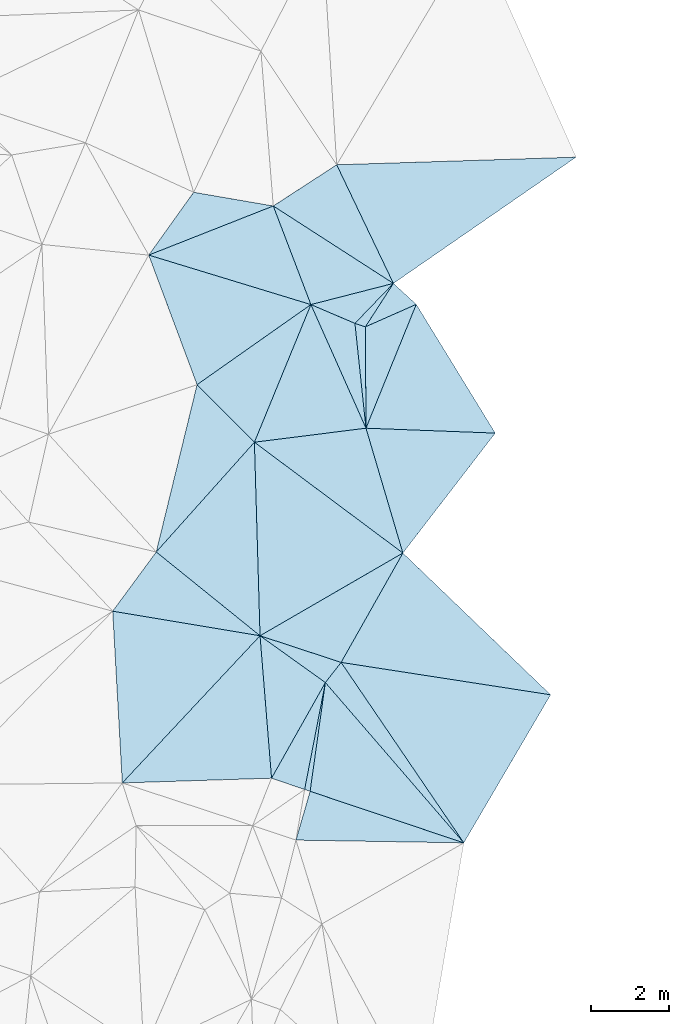
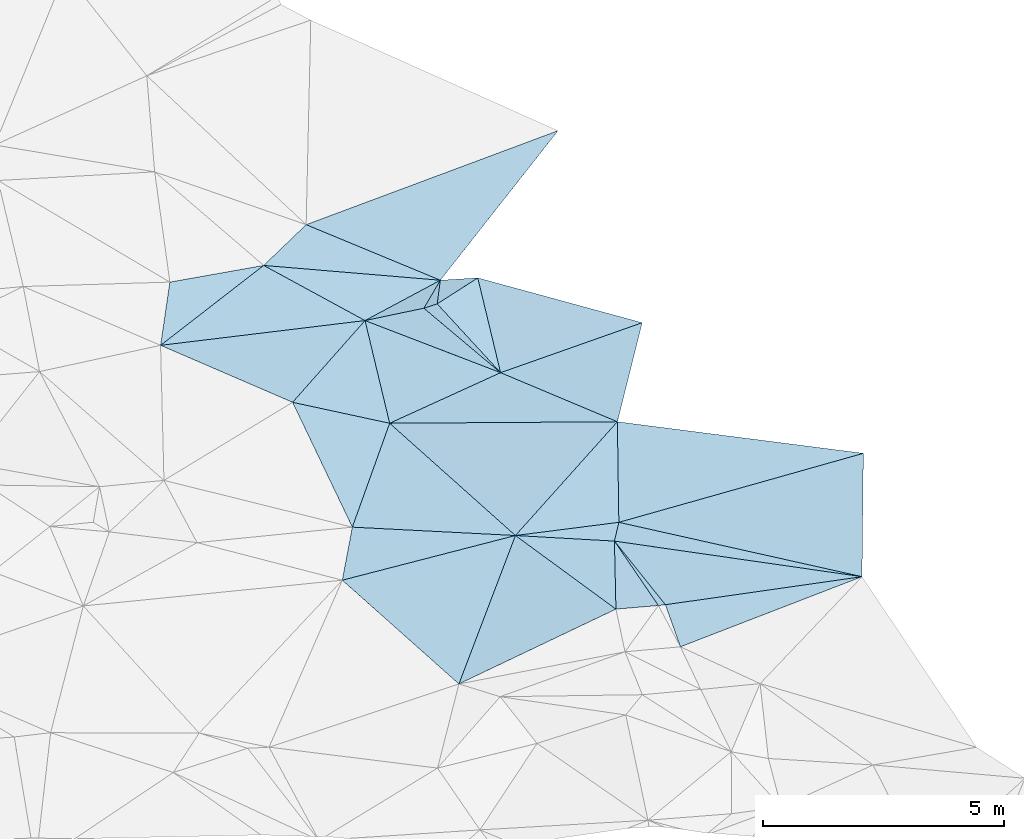
# One storey, part 120 of 275: 33 plates.
"""IFC2X3 building model written with IfcOpenShell, lengths in millimetres."""

from ifc_helpers import new_model, si_unit, frame, origin_with_axes, place, context, subcontext, project, spatial, polyline, outline, extrude, material, type_object, element, save


model = new_model("IFC2X3")

# Units and contexts
model_context = context("Model", 3, precision=1e-05, world=origin_with_axes())
body_context = subcontext(model_context, "Body", "Model", "MODEL_VIEW")
ifc_project = project(units=[si_unit("LENGTHUNIT", "METRE", prefix="MILLI"), si_unit("AREAUNIT", "SQUARE_METRE"), si_unit("VOLUMEUNIT", "CUBIC_METRE"), si_unit("MASSUNIT", "GRAM", prefix="KILO"), si_unit("TIMEUNIT", "SECOND"), si_unit("PLANEANGLEUNIT", "RADIAN"), si_unit("SOLIDANGLEUNIT", "STERADIAN"), si_unit("THERMODYNAMICTEMPERATUREUNIT", "DEGREE_CELSIUS"), si_unit("LUMINOUSINTENSITYUNIT", "LUMEN")], contexts=[model_context])

# Site, building, storey
site_placement = place(None, origin_with_axes())
site = spatial("IfcSite", under=ifc_project, at=site_placement, CompositionType="ELEMENT")
building_placement = place(site_placement, origin_with_axes())
building = spatial("IfcBuilding", under=site, at=building_placement, Name="Undefined", CompositionType="ELEMENT")
storey_placement = place(building_placement, origin_with_axes())
storey = spatial("IfcBuildingStorey", under=building, at=storey_placement, Name="Undefined", CompositionType="ELEMENT", Elevation=0.0)

# Plates
ifc_material = material()
plate_type_1 = type_object("IfcPlateType", PredefinedType="NOTDEFINED")
plate_1_placement = place(storey_placement, frame((-31947.0764014993, 99739.4786818844, 45259.501413125), z_axis=(-0.0397903641696847, 0.0634790782564287, -0.997189617646994), x_axis=(0.83857300788304, -0.54054492477612, -0.067871162865909)))
element("IfcPlate", 1, at=plate_1_placement, inside=storey, type_object=plate_type_1, material=ifc_material, Name="00", context=body_context, shape_type="SweptSolid", body=[
    extrude(outline(polyline([(0.0, 0.0), (3683.44946289063, 2.40106601268053e-09), (2195.46923828125, 1607.36267089844), (0.0, 0.0)])), frame((-8.85201319254618e-08, 2.18876761149539e-07, -0.5000001331573), z_axis=(0.0, 0.0, 1.0), x_axis=(1.0, 0.0, 0.0)), (0.0, 0.0, 1.0), 1.0),
])
plate_type_2 = type_object("IfcPlateType", PredefinedType="NOTDEFINED")
plate_2_placement = place(storey_placement, frame((-32287.5102450675, 88688.02246184, 45229.5048028609), z_axis=(0.125688742627782, -0.057425887442176, -0.990406284020919), x_axis=(0.0804682931812958, -0.994443692263625, 0.0678719139967147)))
element("IfcPlate", 2, at=plate_2_placement, inside=storey, type_object=plate_type_2, material=ifc_material, Name="00", context=body_context, shape_type="SweptSolid", body=[
    extrude(outline(polyline([(0.0, 0.0), (3683.40869140625, 2.38469510804862e-08), (3463.72094726563, 3863.85009765625), (0.0, 0.0)])), frame((-8.85201319254618e-08, 2.18876761149539e-07, -0.5000001331573), z_axis=(0.0, 0.0, 1.0), x_axis=(1.0, 0.0, 0.0)), (0.0, 0.0, 1.0), 1.0),
])
plate_type_3 = type_object("IfcPlateType", PredefinedType="NOTDEFINED")
plate_3_placement = place(storey_placement, frame((-24815.5225647739, 87169.6801998896, 45619.5023801099), z_axis=(0.0774642801000409, 0.058872677691783, -0.99525539090727), x_axis=(-0.985984849721847, 0.152470968813586, -0.0677235541597923)))
element("IfcPlate", 3, at=plate_3_placement, inside=storey, type_object=plate_type_3, material=ifc_material, Name="00", context=body_context, shape_type="SweptSolid", body=[
    extrude(outline(polyline([(0.0, 0.0), (5463.38720703125, -1.55705492943525e-09), (4306.3759765625, 3029.59155273438), (0.0, 0.0)])), frame((-8.85201319254618e-08, 2.18876761149539e-07, -0.5000001331573), z_axis=(0.0, 0.0, 1.0), x_axis=(1.0, 0.0, 0.0)), (0.0, 0.0, 1.0), 1.0),
])
plate_type_4 = type_object("IfcPlateType", PredefinedType="NOTDEFINED")
plate_4_placement = place(storey_placement, frame((-28858.2627816434, 97748.3657133322, 45009.502403774), z_axis=(-0.0951402428778409, -0.0226368225865186, -0.995206465236401), x_axis=(-0.838573007906476, 0.540544924740473, 0.067871162860247)))
element("IfcPlate", 4, at=plate_4_placement, inside=storey, type_object=plate_type_4, material=ifc_material, Name="00", context=body_context, shape_type="SweptSolid", body=[
    extrude(outline(polyline([(0.0, 0.0), (3683.44946289063, 2.40106601268053e-09), (2876.67846679688, 1778.76940917969), (0.0, 0.0)])), frame((-8.85201319254618e-08, 2.18876761149539e-07, -0.5000001331573), z_axis=(0.0, 0.0, 1.0), x_axis=(1.0, 0.0, 0.0)), (0.0, 0.0, 1.0), 1.0),
])
plate_type_5 = type_object("IfcPlateType", PredefinedType="NOTDEFINED")
plate_5_placement = place(storey_placement, frame((-32287.598933863, 88688.0150907528, 45229.5019801013), z_axis=(-0.0516917006701876, -0.072164488813071, -0.996052335289754), x_axis=(0.812956761445989, -0.58232405413073, 1.19901356411449e-10)))
element("IfcPlate", 5, at=plate_5_placement, inside=storey, type_object=plate_type_5, material=ifc_material, Name="00", context=body_context, shape_type="SweptSolid", body=[
    extrude(outline(polyline([(0.0, 0.0), (2066.61547851563, 5.55155565962195e-09), (2373.97802734375, 2816.33251953125), (0.0, 0.0)])), frame((-8.85201319254618e-08, 2.18876761149539e-07, -0.5000001331573), z_axis=(0.0, 0.0, 1.0), x_axis=(1.0, 0.0, 0.0)), (0.0, 0.0, 1.0), 1.0),
])
plate_type_6 = type_object("IfcPlateType", PredefinedType="NOTDEFINED")
plate_6_placement = place(storey_placement, frame((-29562.9329666674, 94025.4960655232, 45169.5198229252), z_axis=(0.271232835832999, 0.0642191774575412, -0.960369015541769), x_axis=(-0.104747662132312, 0.99381505493813, 0.0368722640495097)))
element("IfcPlate", 6, at=plate_6_placement, inside=storey, type_object=plate_type_6, material=ifc_material, Name="00", context=body_context, shape_type="SweptSolid", body=[
    extrude(outline(polyline([(0.0, 0.0), (2712.06567382813, 1.20471668196842e-08), (2598.16723632813, 268.564971923828), (0.0, 0.0)])), frame((-8.85201319254618e-08, 2.18876761149539e-07, -0.5000001331573), z_axis=(0.0, 0.0, 1.0), x_axis=(1.0, 0.0, 0.0)), (0.0, 0.0, 1.0), 1.0),
])
plate_type_7 = type_object("IfcPlateType", PredefinedType="NOTDEFINED")
plate_7_placement = place(storey_placement, frame((-29562.9656143589, 94025.4929305003, 45169.5115833906), z_axis=(0.20593559329297, 0.0579482857713801, -0.976848262316738), x_axis=(-0.406766939989472, 0.912985498686016, -0.0315932860058751)))
element("IfcPlate", 7, at=plate_7_placement, inside=storey, type_object=plate_type_7, material=ifc_material, Name="00", context=body_context, shape_type="SweptSolid", body=[
    extrude(outline(polyline([(0.0, 0.0), (3481.75244140625, 1.64873199537396e-08), (2573.158203125, 856.829406738281), (0.0, 0.0)])), frame((-8.85201319254618e-08, 2.18876761149539e-07, -0.5000001331573), z_axis=(0.0, 0.0, 1.0), x_axis=(1.0, 0.0, 0.0)), (0.0, 0.0, 1.0), 1.0),
])
plate_type_8 = type_object("IfcPlateType", PredefinedType="NOTDEFINED")
plate_8_placement = place(storey_placement, frame((-35149.9201294395, 98476.6222882033, 45119.5053112634), z_axis=(-0.0137765726214369, 0.144619235414847, -0.989391470953147), x_axis=(0.57833080977905, 0.808338448934086, 0.11010189115153)))
element("IfcPlate", 8, at=plate_8_placement, inside=storey, type_object=plate_type_8, material=ifc_material, Name="00", context=body_context, shape_type="SweptSolid", body=[
    extrude(outline(polyline([(0.0, 0.0), (1998.14916992188, 1.33004505187273e-08), (2888.5732421875, 1878.54870605469), (0.0, 0.0)])), frame((-8.85201319254618e-08, 2.18876761149539e-07, -0.5000001331573), z_axis=(0.0, 0.0, 1.0), x_axis=(1.0, 0.0, 0.0)), (0.0, 0.0, 1.0), 1.0),
])
plate_type_9 = type_object("IfcPlateType", PredefinedType="NOTDEFINED")
plate_9_placement = place(storey_placement, frame((-28858.2067715328, 97748.3925237449, 45009.5003200118), z_axis=(0.0168693657021773, 0.0309918933998005, -0.999377269625591), x_axis=(-0.431121930006843, 0.90205628071793, 0.0206965669740174)))
element("IfcPlate", 9, at=plate_9_placement, inside=storey, type_object=plate_type_9, material=ifc_material, Name="00", context=body_context, shape_type="SweptSolid", body=[
    extrude(outline(polyline([(0.0, 0.0), (3382.20336914063, 1.5152181731537e-08), (907.160095214844, 5641.49462890625), (0.0, 0.0)])), frame((-8.85201319254618e-08, 2.18876761149539e-07, -0.5000001331573), z_axis=(0.0, 0.0, 1.0), x_axis=(1.0, 0.0, 0.0)), (0.0, 0.0, 1.0), 1.0),
])
plate_type_10 = type_object("IfcPlateType", PredefinedType="NOTDEFINED")
plate_10_placement = place(storey_placement, frame((-31947.0510480969, 99739.4883331144, 45259.5017539397), z_axis=(0.0109173941928446, 0.0827813084477188, -0.996507935480557), x_axis=(0.355654302247431, -0.93172276627637, -0.0735030890180993)))
element("IfcPlate", 10, at=plate_10_placement, inside=storey, type_object=plate_type_10, material=ifc_material, Name="00", context=body_context, shape_type="SweptSolid", body=[
    extrude(outline(polyline([(0.0, 0.0), (2720.97412109375, 2.66481947619468e-09), (47.8505096435547, 3445.36059570313), (0.0, 0.0)])), frame((-8.85201319254618e-08, 2.18876761149539e-07, -0.5000001331573), z_axis=(0.0, 0.0, 1.0), x_axis=(1.0, 0.0, 0.0)), (0.0, 0.0, 1.0), 1.0),
])
plate_type_11 = type_object("IfcPlateType", PredefinedType="NOTDEFINED")
plate_11_placement = place(storey_placement, frame((-28858.2045337299, 97748.2290168658, 45009.5225367802), z_axis=(0.0213483557747911, -0.296020982648424, -0.954942838884912), x_axis=(0.719402969170723, -0.658737111025358, 0.220283423131005)))
element("IfcPlate", 11, at=plate_11_placement, inside=storey, type_object=plate_type_11, material=ifc_material, Name="00", context=body_context, shape_type="SweptSolid", body=[
    extrude(outline(polyline([(0.0, 0.0), (817.129150390625, -2.46654963120818e-09), (290.162231445313, 1337.79895019531), (0.0, 0.0)])), frame((-8.85201319254618e-08, 2.18876761149539e-07, -0.5000001331573), z_axis=(0.0, 0.0, 1.0), x_axis=(1.0, 0.0, 0.0)), (0.0, 0.0, 1.0), 1.0),
])
plate_type_12 = type_object("IfcPlateType", PredefinedType="NOTDEFINED")
plate_12_placement = place(storey_placement, frame((-29578.1961932674, 96631.715354002, 45339.5365535089), z_axis=(0.124272656391825, -0.354112938375241, -0.926909021289885), x_axis=(-0.921752601176716, 0.304619144949712, -0.239956910202777)))
element("IfcPlate", 12, at=plate_12_placement, inside=storey, type_object=plate_type_12, material=ifc_material, Name="00", context=body_context, shape_type="SweptSolid", body=[
    extrude(outline(polyline([(0.0, 0.0), (291.719055175781, 7.71251507103443e-10), (-244.41325378418, 1346.90832519531), (0.0, 0.0)])), frame((-8.85201319254618e-08, 2.18876761149539e-07, -0.5000001331573), z_axis=(0.0, 0.0, 1.0), x_axis=(1.0, 0.0, 0.0)), (0.0, 0.0, 1.0), 1.0),
])
plate_type_13 = type_object("IfcPlateType", PredefinedType="NOTDEFINED")
plate_13_placement = place(storey_placement, frame((-29847.1249116046, 96720.6095890177, 45269.5225254985), z_axis=(0.0524085230011491, -0.292052716675454, -0.954965212664485), x_axis=(-0.906556038486305, 0.387145296667907, -0.168150731047879)))
element("IfcPlate", 13, at=plate_13_placement, inside=storey, type_object=plate_type_13, material=ifc_material, Name="00", context=body_context, shape_type="SweptSolid", body=[
    extrude(outline(polyline([(0.0, 0.0), (1248.87951660156, 1.13504938781261e-09), (-454.967834472656, 1376.4462890625), (0.0, 0.0)])), frame((-8.85201319254618e-08, 2.18876761149539e-07, -0.5000001331573), z_axis=(0.0, 0.0, 1.0), x_axis=(1.0, 0.0, 0.0)), (0.0, 0.0, 1.0), 1.0),
])
plate_type_14 = type_object("IfcPlateType", PredefinedType="NOTDEFINED")
plate_14_placement = place(storey_placement, frame((-29563.1392929744, 94025.4957637406, 45169.5060561296), z_axis=(-0.141423132068093, 0.0636101894912084, -0.987903457585276), x_axis=(-0.00581534614063085, 0.997862846231412, 0.0650839600839586)))
element("IfcPlate", 14, at=plate_14_placement, inside=storey, type_object=plate_type_14, material=ifc_material, Name="00", context=body_context, shape_type="SweptSolid", body=[
    extrude(outline(polyline([(0.0, 0.0), (2612.0107421875, 1.61235220730305e-08), (3171.61791992188, 1324.47717285156), (0.0, 0.0)])), frame((-8.85201319254618e-08, 2.18876761149539e-07, -0.5000001331573), z_axis=(0.0, 0.0, 1.0), x_axis=(1.0, 0.0, 0.0)), (0.0, 0.0, 1.0), 1.0),
])
plate_type_15 = type_object("IfcPlateType", PredefinedType="NOTDEFINED")
plate_15_placement = place(storey_placement, frame((-28270.3433584745, 97210.096036345, 45189.5007831595), z_axis=(0.0534648212176145, -0.0154318495231273, -0.998450484957799), x_axis=(0.522681865927894, -0.851534131650423, 0.0411496010247286)))
element("IfcPlate", 15, at=plate_15_placement, inside=storey, type_object=plate_type_15, material=ifc_material, Name="00", context=body_context, shape_type="SweptSolid", body=[
    extrude(outline(polyline([(0.0, 0.0), (3888.25146484375, -2.18460627365857e-08), (2035.33642578125, 2769.62182617188), (0.0, 0.0)])), frame((-8.85201319254618e-08, 2.18876761149539e-07, -0.5000001331573), z_axis=(0.0, 0.0, 1.0), x_axis=(1.0, 0.0, 0.0)), (0.0, 0.0, 1.0), 1.0),
])
plate_type_16 = type_object("IfcPlateType", PredefinedType="NOTDEFINED")
plate_16_placement = place(storey_placement, frame((-35149.9285629851, 98476.5232907283, 45119.5009548384), z_axis=(-0.030642054602847, -0.0533751123196366, -0.998104284067844), x_axis=(0.956392208376853, -0.291761255973799, -0.0137591158378074)))
element("IfcPlate", 16, at=plate_16_placement, inside=storey, type_object=plate_type_16, material=ifc_material, Name="00", context=body_context, shape_type="SweptSolid", body=[
    extrude(outline(polyline([(0.0, 0.0), (4360.7451171875, 1.20344338938594e-08), (2159.28686523438, 2829.07763671875), (0.0, 0.0)])), frame((-8.85201319254618e-08, 2.18876761149539e-07, -0.5000001331573), z_axis=(0.0, 0.0, 1.0), x_axis=(1.0, 0.0, 0.0)), (0.0, 0.0, 1.0), 1.0),
])
plate_type_17 = type_object("IfcPlateType", PredefinedType="NOTDEFINED")
plate_17_placement = place(storey_placement, frame((-28613.9039206483, 90815.0505661536, 45539.5031298382), z_axis=(0.0500069467203767, -0.0997475547357358, -0.993755367584974), x_axis=(-0.281801424129214, 0.95316321606647, -0.109853725000888)))
element("IfcPlate", 17, at=plate_17_placement, inside=storey, type_object=plate_type_17, material=ifc_material, Name="00", context=body_context, shape_type="SweptSolid", body=[
    extrude(outline(polyline([(0.0, 0.0), (3368.115234375, -8.7011358118616e-09), (2290.92529296875, 3153.373046875), (0.0, 0.0)])), frame((-8.85201319254618e-08, 2.18876761149539e-07, -0.5000001331573), z_axis=(0.0, 0.0, 1.0), x_axis=(1.0, 0.0, 0.0)), (0.0, 0.0, 1.0), 1.0),
])
plate_type_18 = type_object("IfcPlateType", PredefinedType="NOTDEFINED")
plate_18_placement = place(storey_placement, frame((-29563.051616531, 94025.4116955664, 45169.5030356652), z_axis=(0.0339340701248476, -0.104521168819293, -0.993943561855205), x_axis=(0.281801424133708, -0.953163216065591, 0.109853724996986)))
element("IfcPlate", 18, at=plate_18_placement, inside=storey, type_object=plate_type_18, material=ifc_material, Name="00", context=body_context, shape_type="SweptSolid", body=[
    extrude(outline(polyline([(0.0, 0.0), (3368.115234375, -8.7011358118616e-09), (-471.094329833984, 2853.67651367188), (0.0, 0.0)])), frame((-8.85201319254618e-08, 2.18876761149539e-07, -0.5000001331573), z_axis=(0.0, 0.0, 1.0), x_axis=(1.0, 0.0, 0.0)), (0.0, 0.0, 1.0), 1.0),
])
plate_type_19 = type_object("IfcPlateType", PredefinedType="NOTDEFINED")
plate_19_placement = place(storey_placement, frame((-33906.5839716309, 95144.810040433, 45259.5013005571), z_axis=(-0.0459784281056188, 0.0552753546257971, -0.99741196068622), x_axis=(0.703905297255413, -0.706674697039154, -0.0716114869304335)))
element("IfcPlate", 19, at=plate_19_placement, inside=storey, type_object=plate_type_19, material=ifc_material, Name="00", context=body_context, shape_type="SweptSolid", body=[
    extrude(outline(polyline([(0.0, 0.0), (2094.63598632813, 3.39059624820948e-09), (2314.48315429688, 3780.1279296875), (0.0, 0.0)])), frame((-8.85201319254618e-08, 2.18876761149539e-07, -0.5000001331573), z_axis=(0.0, 0.0, 1.0), x_axis=(1.0, 0.0, 0.0)), (0.0, 0.0, 1.0), 1.0),
])
plate_type_20 = type_object("IfcPlateType", PredefinedType="NOTDEFINED")
plate_20_placement = place(storey_placement, frame((-30979.3712688772, 97204.2631837884, 45059.501778422), z_axis=(-0.0817997348758805, 0.0194977636585109, -0.996458047579803), x_axis=(-0.379663017995436, -0.925032571354974, 0.013066548855843)))
element("IfcPlate", 20, at=plate_20_placement, inside=storey, type_object=plate_type_20, material=ifc_material, Name="00", context=body_context, shape_type="SweptSolid", body=[
    extrude(outline(polyline([(0.0, 0.0), (3826.56494140625, -6.44649844616652e-09), (3019.05224609375, 1932.72424316406), (0.0, 0.0)])), frame((-8.85201319254618e-08, 2.18876761149539e-07, -0.5000001331573), z_axis=(0.0, 0.0, 1.0), x_axis=(1.0, 0.0, 0.0)), (0.0, 0.0, 1.0), 1.0),
])
plate_type_21 = type_object("IfcPlateType", PredefinedType="NOTDEFINED")
plate_21_placement = place(storey_placement, frame((-32432.087477343, 93664.5455385043, 45109.5024410617), z_axis=(0.0962488879862037, -0.0211999789077481, -0.995131505106602), x_axis=(0.798183879320171, -0.59566959008706, 0.0898901231444088)))
element("IfcPlate", 21, at=plate_21_placement, inside=storey, type_object=plate_type_21, material=ifc_material, Name="00", context=body_context, shape_type="SweptSolid", body=[
    extrude(outline(polyline([(0.0, 0.0), (4783.61767578125, -4.27826307713985e-09), (3090.52685546875, 3905.06640625), (0.0, 0.0)])), frame((-8.85201319254618e-08, 2.18876761149539e-07, -0.5000001331573), z_axis=(0.0, 0.0, 1.0), x_axis=(1.0, 0.0, 0.0)), (0.0, 0.0, 1.0), 1.0),
])
plate_type_22 = type_object("IfcPlateType", PredefinedType="NOTDEFINED")
plate_22_placement = place(storey_placement, frame((-32432.1236452497, 93664.5441731473, 45109.5002929133), z_axis=(0.0239111370494598, -0.0239313131739074, -0.999427611072845), x_axis=(0.379663018005795, 0.925032571350765, -0.0130665488527914)))
element("IfcPlate", 22, at=plate_22_placement, inside=storey, type_object=plate_type_22, material=ifc_material, Name="00", context=body_context, shape_type="SweptSolid", body=[
    extrude(outline(polyline([(0.0, 0.0), (3826.56494140625, -6.44649844616652e-09), (1422.34619140625, 2518.39868164063), (0.0, 0.0)])), frame((-8.85201319254618e-08, 2.18876761149539e-07, -0.5000001331573), z_axis=(0.0, 0.0, 1.0), x_axis=(1.0, 0.0, 0.0)), (0.0, 0.0, 1.0), 1.0),
])
plate_type_23 = type_object("IfcPlateType", PredefinedType="NOTDEFINED")
plate_23_placement = place(storey_placement, frame((-28613.9106624089, 90815.1414722324, 45539.5020286736), z_axis=(0.0365273125531285, 0.0820659948352251, -0.995957292221585), x_axis=(-0.48980744759684, -0.867232473590122, -0.0894231571206685)))
element("IfcPlate", 23, at=plate_23_placement, inside=storey, type_object=plate_type_23, material=ifc_material, Name="00", context=body_context, shape_type="SweptSolid", body=[
    extrude(outline(polyline([(0.0, 0.0), (3243.0078125, 1.50903360918164e-08), (3671.74560546875, 2152.76196289063), (0.0, 0.0)])), frame((-8.85201319254618e-08, 2.18876761149539e-07, -0.5000001331573), z_axis=(0.0, 0.0, 1.0), x_axis=(1.0, 0.0, 0.0)), (0.0, 0.0, 1.0), 1.0),
])
plate_type_24 = type_object("IfcPlateType", PredefinedType="NOTDEFINED")
plate_24_placement = place(storey_placement, frame((-32287.5493203419, 88688.043532295, 45229.5006303649), z_axis=(0.0475337500640067, -0.0152799712002028, -0.998752754732108), x_axis=(-0.985173991852321, 0.16429165182993, -0.0494010011716034)))
element("IfcPlate", 24, at=plate_24_placement, inside=storey, type_object=plate_type_24, material=ifc_material, Name="00", context=body_context, shape_type="SweptSolid", body=[
    extrude(outline(polyline([(0.0, 0.0), (3846.07592773438, -1.52795109897852e-09), (2991.5166015625, 1686.36547851563), (0.0, 0.0)])), frame((-8.85201319254618e-08, 2.18876761149539e-07, -0.5000001331573), z_axis=(0.0, 0.0, 1.0), x_axis=(1.0, 0.0, 0.0)), (0.0, 0.0, 1.0), 1.0),
])
plate_type_25 = type_object("IfcPlateType", PredefinedType="NOTDEFINED")
plate_25_placement = place(storey_placement, frame((-30607.5164451025, 87484.5737561121, 45229.5015668394), z_axis=(-0.024949115325276, -0.0748964060397014, -0.996879165198482), x_axis=(-0.138466725853599, -0.98731881502548, 0.0776435659154429)))
element("IfcPlate", 25, at=plate_25_placement, inside=storey, type_object=plate_type_25, material=ifc_material, Name="00", context=body_context, shape_type="SweptSolid", body=[
    extrude(outline(polyline([(0.0, 0.0), (2833.46069335938, -1.96887413039804e-08), (2806.60327148438, 146.214462280273), (0.0, 0.0)])), frame((-8.85201319254618e-08, 2.18876761149539e-07, -0.5000001331573), z_axis=(0.0, 0.0, 1.0), x_axis=(1.0, 0.0, 0.0)), (0.0, 0.0, 1.0), 1.0),
])
plate_type_26 = type_object("IfcPlateType", PredefinedType="NOTDEFINED")
plate_26_placement = place(storey_placement, frame((-27046.6453437336, 83362.3745866853, 45579.5015898639), z_axis=(0.00622020512759254, -0.0792642205016435, -0.996834235164723), x_axis=(-0.947722436295677, 0.317570284923594, -0.0311656521724504)))
element("IfcPlate", 26, at=plate_26_placement, inside=storey, type_object=plate_type_26, material=ifc_material, Name="00", context=body_context, shape_type="SweptSolid", body=[
    extrude(outline(polyline([(0.0, 0.0), (4171.2587890625, 5.4424162954092e-09), (4694.69775390625, 2784.6923828125), (0.0, 0.0)])), frame((-8.85201319254618e-08, 2.18876761149539e-07, -0.5000001331573), z_axis=(0.0, 0.0, 1.0), x_axis=(1.0, 0.0, 0.0)), (0.0, 0.0, 1.0), 1.0),
])
plate_type_27 = type_object("IfcPlateType", PredefinedType="NOTDEFINED")
plate_27_placement = place(storey_placement, frame((-35829.4057092821, 84902.6856658711, 44999.5007193538), z_axis=(0.0520667039973309, 0.0119562015886953, -0.998572034246115), x_axis=(-0.0558716591905781, 0.998397025212047, 0.00904089304372428)))
element("IfcPlate", 27, at=plate_27_placement, inside=storey, type_object=plate_type_27, material=ifc_material, Name="00", context=body_context, shape_type="SweptSolid", body=[
    extrude(outline(polyline([(0.0, 0.0), (4424.341796875, 1.10994733404368e-08), (3583.49340820313, 3753.03540039063), (0.0, 0.0)])), frame((-8.85201319254618e-08, 2.18876761149539e-07, -0.5000001331573), z_axis=(0.0, 0.0, 1.0), x_axis=(1.0, 0.0, 0.0)), (0.0, 0.0, 1.0), 1.0),
])
plate_type_28 = type_object("IfcPlateType", PredefinedType="NOTDEFINED")
plate_28_placement = place(storey_placement, frame((-30607.5332316816, 87484.5770489256, 45229.5020334972), z_axis=(-0.058521213394682, -0.0683115393395424, -0.995946183875352), x_axis=(-0.189787729911003, -0.978699542358186, 0.0782804149395335)))
element("IfcPlate", 28, at=plate_28_placement, inside=storey, type_object=plate_type_28, material=ifc_material, Name="00", context=body_context, shape_type="SweptSolid", body=[
    extrude(outline(polyline([(0.0, 0.0), (2810.4091796875, -1.06083462014794e-08), (2689.2880859375, 891.027282714844), (0.0, 0.0)])), frame((-8.85201319254618e-08, 2.18876761149539e-07, -0.5000001331573), z_axis=(0.0, 0.0, 1.0), x_axis=(1.0, 0.0, 0.0)), (0.0, 0.0, 1.0), 1.0),
])
plate_type_29 = type_object("IfcPlateType", PredefinedType="NOTDEFINED")
plate_29_placement = place(storey_placement, frame((-27046.611924548, 83362.4746568623, 45579.5050191715), z_axis=(0.0730587360216794, 0.120874555670599, -0.989975637519606), x_axis=(-0.997299838850946, 0.0162659148254721, -0.0716132071811371)))
element("IfcPlate", 29, at=plate_29_placement, inside=storey, type_object=plate_type_29, material=ifc_material, Name="00", context=body_context, shape_type="SweptSolid", body=[
    extrude(outline(polyline([(0.0, 0.0), (4328.810546875, 6.83940015733242e-10), (3973.3779296875, 1269.51477050781), (0.0, 0.0)])), frame((-8.85201319254618e-08, 2.18876761149539e-07, -0.5000001331573), z_axis=(0.0, 0.0, 1.0), x_axis=(1.0, 0.0, 0.0)), (0.0, 0.0, 1.0), 1.0),
])
plate_type_30 = type_object("IfcPlateType", PredefinedType="NOTDEFINED")
plate_30_placement = place(storey_placement, frame((-30202.369474845, 88002.6710767021, 45249.5002379828), z_axis=(0.0177168109382952, 0.0247336536558453, -0.99953707334296), x_axis=(-0.615737969058283, -0.787364434360541, -0.030397384165174)))
element("IfcPlate", 30, at=plate_30_placement, inside=storey, type_object=plate_type_30, material=ifc_material, Name="00", context=body_context, shape_type="SweptSolid", body=[
    extrude(outline(polyline([(0.0, 0.0), (657.951354980469, 3.66708263754845e-09), (744.887878417969, 2064.7861328125), (0.0, 0.0)])), frame((-8.85201319254618e-08, 2.18876761149539e-07, -0.5000001331573), z_axis=(0.0, 0.0, 1.0), x_axis=(1.0, 0.0, 0.0)), (0.0, 0.0, 1.0), 1.0),
])
plate_type_31 = type_object("IfcPlateType", PredefinedType="NOTDEFINED")
plate_31_placement = place(storey_placement, frame((-27046.6162978219, 83362.4006169606, 45579.501227367), z_axis=(0.0643113575556819, -0.027206579578001, -0.997558946286891), x_axis=(-0.561384482314616, 0.825470287182163, -0.0587049230963456)))
element("IfcPlate", 31, at=plate_31_placement, inside=storey, type_object=plate_type_31, material=ifc_material, Name="00", context=body_context, shape_type="SweptSolid", body=[
    extrude(outline(polyline([(0.0, 0.0), (5621.33447265625, 1.89756974577904e-08), (1887.91479492188, 3988.75634765625), (0.0, 0.0)])), frame((-8.85201319254618e-08, 2.18876761149539e-07, -0.5000001331573), z_axis=(0.0, 0.0, 1.0), x_axis=(1.0, 0.0, 0.0)), (0.0, 0.0, 1.0), 1.0),
])
plate_type_32 = type_object("IfcPlateType", PredefinedType="NOTDEFINED")
plate_32_placement = place(storey_placement, frame((-27046.611043697, 83362.404211497, 45579.5015088203), z_axis=(0.07481954539587, -0.0200201598457298, -0.9969961027138), x_axis=(-0.652356274861306, 0.755195220597561, -0.0641207410724572)))
element("IfcPlate", 32, at=plate_32_placement, inside=storey, type_object=plate_type_32, material=ifc_material, Name="00", context=body_context, shape_type="SweptSolid", body=[
    extrude(outline(polyline([(0.0, 0.0), (5458.4521484375, -9.74978320300579e-09), (5584.1103515625, 645.840515136719), (0.0, 0.0)])), frame((-8.85201319254618e-08, 2.18876761149539e-07, -0.5000001331573), z_axis=(0.0, 0.0, 1.0), x_axis=(1.0, 0.0, 0.0)), (0.0, 0.0, 1.0), 1.0),
])
plate_type_33 = type_object("IfcPlateType", PredefinedType="NOTDEFINED")
plate_33_placement = place(storey_placement, frame((-32287.5523878854, 88688.0397333042, 45229.50056577), z_axis=(0.0414032813669181, -0.022883587438856, -0.998880428138413), x_axis=(-0.777259268168087, 0.627452986919121, -0.0465916221340702)))
element("IfcPlate", 33, at=plate_33_placement, inside=storey, type_object=plate_type_33, material=ifc_material, Name="00", context=body_context, shape_type="SweptSolid", body=[
    extrude(outline(polyline([(0.0, 0.0), (3434.09375, -1.19689502753317e-08), (3240.4765625, 3781.56225585938), (0.0, 0.0)])), frame((-8.85201319254618e-08, 2.18876761149539e-07, -0.5000001331573), z_axis=(0.0, 0.0, 1.0), x_axis=(1.0, 0.0, 0.0)), (0.0, 0.0, 1.0), 1.0),
])

save(model, "model.ifc")
